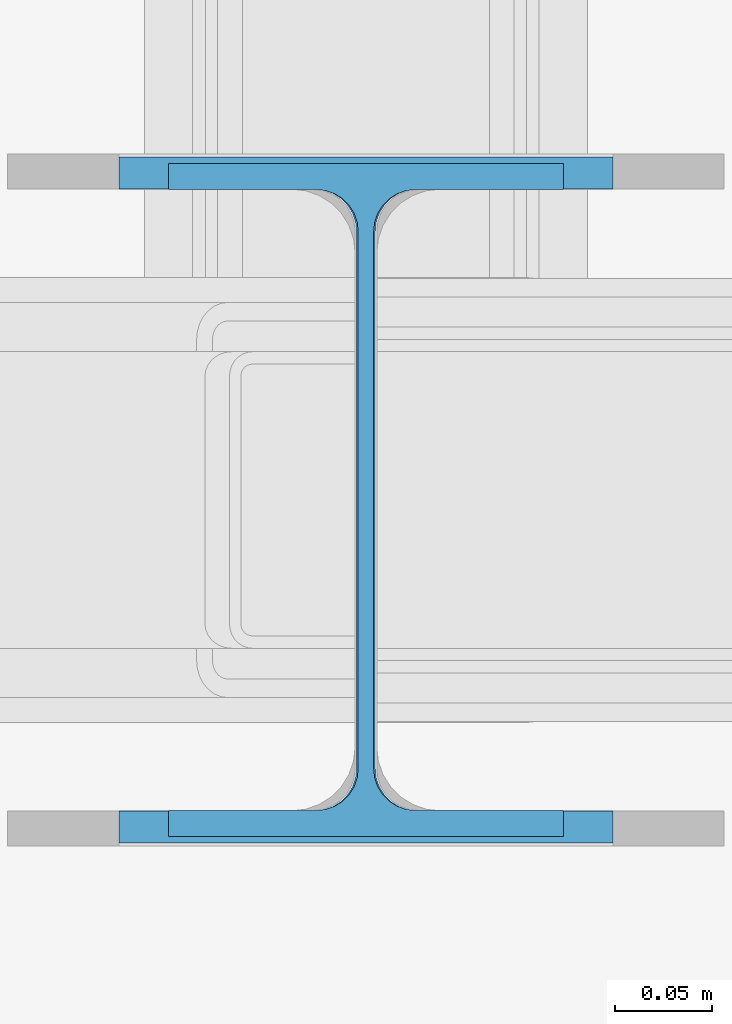
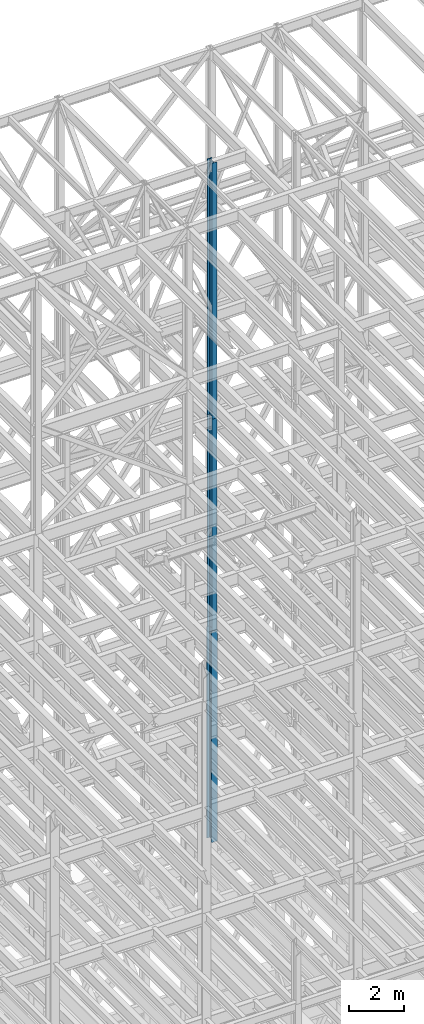
# One storey, part 46 of 150: 3 columns.
"""IFC2X3 building model written with IfcOpenShell, lengths in millimetres."""

from ifc_helpers import new_model, si_unit, frame, origin_with_axes, origin_2d_with_axis, place, context, subcontext, project, spatial, i_section, extrude, material, type_object, element, save


model = new_model("IFC2X3")

# Units and contexts
model_context = context("Model", 3, precision=1e-05, world=origin_with_axes())
body_context = subcontext(model_context, "Body", "Model", "MODEL_VIEW")
ifc_project = project(units=[si_unit("LENGTHUNIT", "METRE", prefix="MILLI"), si_unit("AREAUNIT", "SQUARE_METRE"), si_unit("VOLUMEUNIT", "CUBIC_METRE"), si_unit("MASSUNIT", "GRAM", prefix="KILO"), si_unit("TIMEUNIT", "SECOND"), si_unit("PLANEANGLEUNIT", "RADIAN"), si_unit("SOLIDANGLEUNIT", "STERADIAN"), si_unit("THERMODYNAMICTEMPERATUREUNIT", "DEGREE_CELSIUS"), si_unit("LUMINOUSINTENSITYUNIT", "LUMEN")], contexts=[model_context])

# Site, building, storey
site_placement = place(None, origin_with_axes())
site = spatial("IfcSite", under=ifc_project, at=site_placement, CompositionType="ELEMENT")
building_placement = place(site_placement, origin_with_axes())
building = spatial("IfcBuilding", under=site, at=building_placement, Name="Undefined", CompositionType="ELEMENT")
storey_placement = place(building_placement, origin_with_axes())
storey = spatial("IfcBuildingStorey", under=building, at=storey_placement, Name="Undefined", CompositionType="ELEMENT", Elevation=0.0)

# Columns
ifc_material = material(Name="STEEL/A992")
column_type_1 = type_object("IfcColumnType", Name="W14X43", PredefinedType="NOTDEFINED")
column_1_placement = place(storey_placement, frame((59436.0, 25628.6, 54483.0), z_axis=(0.0, 0.0, 1.0), x_axis=(1.0, 0.0, 0.0)))
element("IfcColumn", 1, at=column_1_placement, inside=storey, type_object=column_type_1, material=ifc_material, Name="COLUMN", ObjectType="W14X43", context=body_context, shape_type="SweptSolid", body=[
    extrude(i_section(OverallWidth=203.2, OverallDepth=346.075, WebThickness=7.9375, FlangeThickness=13.462, FilletRadius=21.4629, at=origin_2d_with_axis()), frame((0.0, 0.0, 11429.998857), z_axis=(0.0, 0.0, -1.0), x_axis=(-1.0, 0.0, 0.0)), (0.0, 0.0, 1.0), 11429.998857),
])
column_2_placement = place(storey_placement, frame((59436.0, 25628.6, 45034.2), z_axis=(0.0, 0.0, 1.0), x_axis=(1.0, 0.0, 0.0)))
element("IfcColumn", 2, at=column_2_placement, inside=storey, type_object=column_type_1, material=ifc_material, Name="COLUMN", ObjectType="W14X43", context=body_context, shape_type="SweptSolid", body=[
    extrude(i_section(OverallWidth=203.2, OverallDepth=346.075, WebThickness=7.9375, FlangeThickness=13.462, FilletRadius=21.4629, at=origin_2d_with_axis()), frame((0.0, 0.0, 9448.8), z_axis=(0.0, 0.0, -1.0), x_axis=(-1.0, 0.0, 0.0)), (0.0, 0.0, 1.0), 9448.8),
])
column_type_2 = type_object("IfcColumnType", Name="W14X61", PredefinedType="NOTDEFINED")
column_3_placement = place(storey_placement, frame((59436.0, 25628.6, 35585.4), z_axis=(0.0, 0.0, 1.0), x_axis=(1.0, 0.0, 0.0)))
element("IfcColumn", 3, at=column_3_placement, inside=storey, type_object=column_type_2, material=ifc_material, Name="COLUMN", ObjectType="W14X61", context=body_context, shape_type="SweptSolid", body=[
    extrude(i_section(OverallWidth=254.0, OverallDepth=352.425, WebThickness=9.5249, FlangeThickness=16.383, FilletRadius=21.717, at=origin_2d_with_axis()), frame((0.0, 0.0, 9448.8), z_axis=(0.0, 0.0, -1.0), x_axis=(-1.0, 0.0, 0.0)), (0.0, 0.0, 1.0), 9448.8),
])

save(model, "model.ifc")
